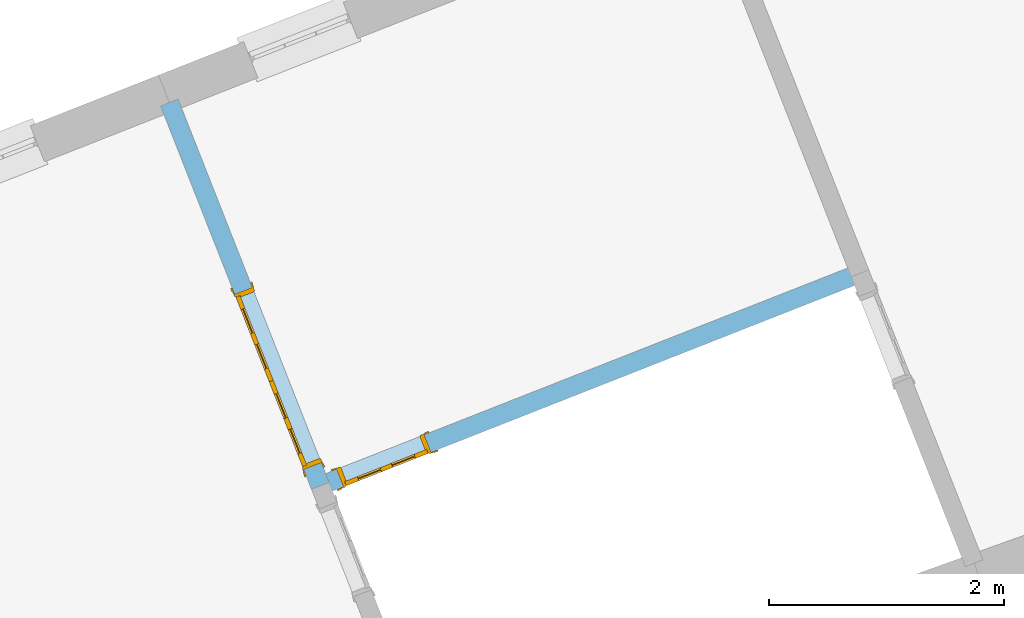
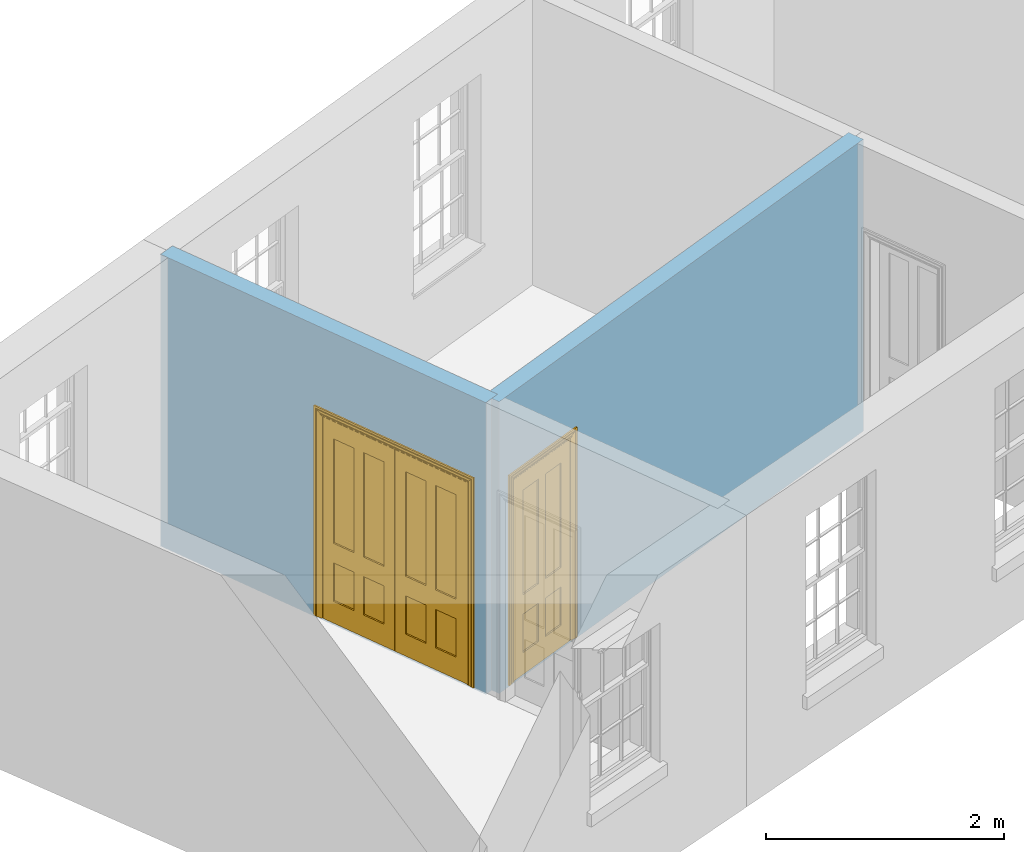
# One storey, part 3 of 6: 2 doors, 2 openings, plus 2 elements that do not belong to this part.
"""IFC2X3 building model written with IfcOpenShell, lengths in metres."""

from ifc_helpers import new_model, si_unit, frame, origin, place, context, subcontext, project, spatial, polyline, outline, extrude, faceted_brep, material, layer, layer_set, layer_usage, element, fill, save


model = new_model("IFC2X3")

# Units and contexts
model_context = context("Model", 3, world=origin())
body_context = subcontext(model_context, "Body", "Model", "MODEL_VIEW")
ifc_project = project(units=[si_unit("PLANEANGLEUNIT", "RADIAN"), si_unit("MASSUNIT", "GRAM", prefix="KILO"), si_unit("FORCEUNIT", "NEWTON", prefix="KILO"), si_unit("LENGTHUNIT", "METRE")], contexts=[model_context])

# Site, building, storey
site_placement = place(None, origin())
site = spatial("IfcSite", under=ifc_project, at=site_placement, CompositionType="ELEMENT")
building_placement = place(None, origin())
building = spatial("IfcBuilding", under=site, at=building_placement, Name="Building plot-4", CompositionType="ELEMENT")
storey_placement = place(None, frame((0.0, 0.0, 6.45)))
storey = spatial("IfcBuildingStorey", under=building, at=storey_placement, Name="Floor 1", CompositionType="ELEMENT", Elevation=6.45)

# Wall, opening, door
ifc_material = material(Name="Masonry")
ifc_layer = layer(ifc_material, 0.16, ventilated=False)
ifc_layer_set = layer_set([ifc_layer], Name="My Wall")
ifc_layer_usage = layer_usage(ifc_layer_set, "AXIS2", "NEGATIVE", 0.08)
wall_1_placement = place(storey_placement, origin())
wall_1 = element("IfcWallStandardCase", 1, at=wall_1_placement, inside=storey, material=ifc_layer_usage, Name="interior", context=body_context, shape_type="SweptSolid", body=[
    extrude(outline(polyline([(53.3188757605398, 50.5174703749296), (53.2602472129912, 50.666341773836), (48.675963659778, 48.860958817468), (48.7345922073266, 48.7120874185616), (53.3188757605398, 50.5174703749296)])), origin(), (0.0, 0.0, 1.0), 3.0),
])
opening_1_placement = place(storey_placement, frame((0.0, 0.0, 0.0199999999999996)))
opening_1 = element("IfcOpeningElement", 2, at=opening_1_placement, cuts=wall_1, Name="Opening", ObjectType="Opening", context=body_context, shape_type="SweptSolid", body=[
    extrude(outline(polyline([(49.5878009780793, 49.2200586712036), (48.8434439835476, 48.9269159334602), (48.9020725310963, 48.7780445345539), (49.646429525628, 49.0711872722973), (49.5878009780793, 49.2200586712036)])), origin(), (0.0, 0.0, 1.0), 2.1),
])
door_1_placement = place(storey_placement, frame((49.6171152518537, 49.1456229717504, 0.0199999999999996), z_axis=(0.0, 0.0, 1.0), x_axis=(-0.744356994531735, -0.293142737743388, 0.0)))
door_1 = element("IfcDoor", 3, at=door_1_placement, inside=storey, Name="living inside door", OverallHeight=2.1, OverallWidth=0.8, context=body_context, shape_type="Brep", held_by="IfcProductRepresentation", body=[
    faceted_brep([(0.773, 0.08, 1.895), (0.66, 0.08, 1.895), (0.66, 0.08, 2.073), (0.773, 0.08, 2.073), (0.773, 0.08, 0.82), (0.66, 0.08, 0.82), (0.45, 0.08, 1.895), (0.45, 0.08, 2.073), (0.773, 0.08, 0.62), (0.66, 0.08, 0.62), (0.66, 0.065, 0.82), (0.66, 0.065, 1.895), (0.45, 0.065, 1.895), (0.35, 0.08, 1.895), (0.35, 0.08, 2.073), (0.773, 0.08, 0.225), (0.66, 0.08, 0.225), (0.45, 0.08, 0.62), (0.45, 0.08, 0.82), (0.45, 0.065, 0.82), (0.35, 0.08, 0.82), (0.14, 0.08, 2.073), (0.14, 0.08, 1.895), (0.773, 0.08, 0.0), (0.66, 0.08, 0.0), (0.66, 0.065, 0.225), (0.66, 0.065, 0.62), (0.45, 0.065, 0.62), (0.35, 0.08, 0.62), (0.35, 0.065, 0.82), (0.35, 0.065, 1.895), (0.14, 0.065, 1.895), (0.027, 0.08, 2.073), (0.027, 0.08, 1.895), (0.773, 0.042, 0.0), (0.66, 0.042, 0.0), (0.45, 0.08, 0.0), (0.45, 0.08, 0.225), (0.45, 0.065, 0.225), (0.35, 0.08, 0.225), (0.14, 0.08, 0.82), (0.14, 0.08, 0.62), (0.14, 0.065, 0.82), (0.027, 0.08, 0.82), (0.773, 0.042, 0.225), (0.66, 0.042, 0.225), (0.45, 0.042, 0.0), (0.35, 0.08, 0.0), (0.35, 0.065, 0.225), (0.35, 0.065, 0.62), (0.14, 0.065, 0.62), (0.027, 0.08, 0.62), (0.773, 0.042, 0.62), (0.66, 0.042, 0.62), (0.45, 0.042, 0.225), (0.35, 0.042, 0.0), (0.14, 0.08, 0.225), (0.14, 0.08, 0.0), (0.14, 0.065, 0.225), (0.027, 0.08, 0.225), (0.773, 0.042, 0.82), (0.66, 0.042, 0.82), (0.66, 0.057, 0.62), (0.66, 0.057, 0.225), (0.45, 0.057, 0.225), (0.35, 0.042, 0.225), (0.14, 0.042, 0.0), (0.027, 0.08, 0.0), (0.773, 0.042, 1.895), (0.66, 0.042, 1.895), (0.45, 0.042, 0.62), (0.45, 0.042, 0.82), (0.45, 0.057, 0.62), (0.35, 0.042, 0.62), (0.14, 0.042, 0.225), (0.027, 0.042, 0.0), (0.773, 0.042, 2.073), (0.66, 0.042, 2.073), (0.66, 0.057, 1.895), (0.66, 0.057, 0.82), (0.45, 0.057, 0.82), (0.35, 0.042, 0.82), (0.35, 0.057, 0.62), (0.35, 0.057, 0.225), (0.14, 0.057, 0.225), (0.027, 0.042, 0.225), (0.45, 0.042, 1.895), (0.45, 0.042, 2.073), (0.45, 0.057, 1.895), (0.35, 0.042, 1.895), (0.14, 0.042, 0.82), (0.14, 0.042, 0.62), (0.14, 0.057, 0.62), (0.027, 0.042, 0.62), (0.35, 0.042, 2.073), (0.35, 0.057, 1.895), (0.35, 0.057, 0.82), (0.14, 0.057, 0.82), (0.027, 0.042, 0.82), (0.14, 0.042, 2.073), (0.14, 0.042, 1.895), (0.14, 0.057, 1.895), (0.027, 0.042, 1.895), (0.027, 0.042, 2.073), (0.02, 0.085, 0.0), (0.005, 0.09, 0.0), (0.005, 0.09, 2.095), (0.02, 0.085, 2.08), (0.02, 0.08, 0.0), (0.0, 0.085, 0.0), (0.0, 0.085, 2.1), (0.795, 0.09, 2.095), (0.78, 0.085, 2.08), (0.02, 0.08, 2.08), (0.0, 0.08, 0.0), (-0.032, 0.095, 0.0), (-0.032, 0.095, 2.132), (0.8, 0.085, 2.1), (0.795, 0.09, 0.0), (0.78, 0.085, 0.0), (0.78, 0.08, 2.08), (0.04, 0.04, 0.0), (0.025, 0.04, 0.0), (0.025, 0.04, 2.075), (0.04, 0.04, 2.06), (-0.04, 0.09, 0.0), (-0.04, 0.09, 2.14), (0.832, 0.095, 2.132), (0.8, 0.085, 0.0), (0.78, 0.08, 0.0), (0.8, 0.08, 0.0), (0.86, 0.08, 0.0), (0.86, 0.08, 2.16), (0.8, 0.08, 2.1), (-0.06, 0.08, 2.16), (0.0, 0.08, 2.1), (-0.06, 0.08, 0.0), (-0.04, 0.095, 0.0), (-0.04, 0.095, 2.14), (0.84, 0.09, 2.14), (0.832, 0.095, 0.0), (0.84, 0.09, 0.0), (0.86, 0.095, 0.0), (0.86, 0.095, 2.16), (-0.06, 0.095, 2.16), (-0.06, 0.095, 0.0), (0.84, 0.095, 0.0), (0.84, 0.095, 2.14), (-0.025, -0.095, 0.0), (-0.025, -0.09, 0.0), (-0.025, -0.09, 2.125), (-0.025, -0.095, 2.125), (-0.017, -0.095, 0.0), (-0.017, -0.095, 2.117), (0.825, -0.09, 2.125), (0.825, -0.095, 2.125), (0.825, -0.095, 0.0), (0.845, -0.095, 0.0), (-0.045, -0.095, 2.145), (-0.045, -0.095, 0.0), (0.845, -0.095, 2.145), (0.015, -0.085, 0.0), (0.015, -0.085, 2.085), (0.817, -0.095, 2.117), (0.825, -0.09, 0.0), (0.845, -0.08, 0.0), (0.845, -0.08, 2.145), (-0.045, -0.08, 2.145), (-0.045, -0.08, 0.0), (0.02, -0.09, 0.0), (0.02, -0.09, 2.08), (0.785, -0.085, 2.085), (0.817, -0.095, 0.0), (0.8, -0.08, 0.0), (0.8, -0.08, 2.1), (0.0, -0.08, 2.1), (0.0, -0.08, 0.0), (0.035, -0.085, 0.0), (0.035, -0.085, 2.065), (0.78, -0.09, 2.08), (0.785, -0.085, 0.0), (0.775, 0.04, 2.075), (0.76, 0.04, 2.06), (0.035, -0.08, 2.065), (0.035, -0.08, 0.0), (0.765, -0.085, 2.065), (0.78, -0.09, 0.0), (0.765, -0.08, 0.0), (0.765, -0.08, 2.065), (0.765, -0.085, 0.0), (0.04, -0.08, 2.06), (0.04, -0.08, 0.0), (0.76, -0.08, 2.06), (0.76, -0.08, 0.0), (0.76, 0.04, 0.0), (0.775, 0.04, 0.0), (0.025, 0.08, 0.0), (0.025, 0.08, 2.075), (0.775, 0.08, 0.0), (0.775, 0.08, 2.075)], [[[0, 1, 2, 3]], [[1, 0, 4, 5]], [[1, 6, 7, 2]], [[8, 9, 5, 4]], [[1, 5, 10, 11]], [[6, 1, 11, 12]], [[6, 13, 14, 7]], [[15, 16, 9, 8]], [[9, 17, 18, 5]], [[5, 18, 19, 10]], [[10, 19, 12, 11]], [[18, 6, 12, 19]], [[18, 20, 13, 6]], [[21, 14, 13, 22]], [[23, 24, 16, 15]], [[9, 16, 25, 26]], [[17, 9, 26, 27]], [[17, 28, 20, 18]], [[13, 20, 29, 30]], [[22, 13, 30, 31]], [[32, 21, 22, 33]], [[34, 35, 24, 23]], [[24, 36, 37, 16]], [[16, 37, 38, 25]], [[25, 38, 27, 26]], [[37, 17, 27, 38]], [[37, 39, 28, 17]], [[40, 20, 28, 41]], [[20, 40, 42, 29]], [[31, 30, 29, 42]], [[40, 22, 31, 42]], [[33, 22, 40, 43]], [[35, 34, 44, 45]], [[35, 46, 36, 24]], [[36, 47, 39, 37]], [[28, 39, 48, 49]], [[41, 28, 49, 50]], [[43, 40, 41, 51]], [[45, 44, 52, 53]], [[46, 35, 45, 54]], [[46, 55, 47, 36]], [[56, 39, 47, 57]], [[39, 56, 58, 48]], [[50, 49, 48, 58]], [[56, 41, 50, 58]], [[51, 41, 56, 59]], [[53, 52, 60, 61]], [[45, 53, 62, 63]], [[54, 45, 63, 64]], [[55, 46, 54, 65]], [[55, 66, 57, 47]], [[59, 56, 57, 67]], [[61, 60, 68, 69]], [[70, 53, 61, 71]], [[53, 70, 72, 62]], [[72, 64, 63, 62]], [[70, 54, 64, 72]], [[65, 54, 70, 73]], [[65, 74, 66, 55]], [[67, 57, 66, 75]], [[69, 68, 76, 77]], [[61, 69, 78, 79]], [[71, 61, 79, 80]], [[73, 70, 71, 81]], [[65, 73, 82, 83]], [[74, 65, 83, 84]], [[74, 85, 75, 66]], [[86, 69, 77, 87]], [[69, 86, 88, 78]], [[88, 80, 79, 78]], [[86, 71, 80, 88]], [[81, 71, 86, 89]], [[73, 81, 90, 91]], [[73, 91, 92, 82]], [[83, 82, 92, 84]], [[91, 74, 84, 92]], [[91, 93, 85, 74]], [[89, 86, 87, 94]], [[81, 89, 95, 96]], [[90, 81, 96, 97]], [[90, 98, 93, 91]], [[94, 99, 100, 89]], [[89, 100, 101, 95]], [[101, 97, 96, 95]], [[100, 90, 97, 101]], [[100, 102, 98, 90]], [[99, 103, 102, 100]], [[32, 103, 99, 21]], [[102, 103, 32, 33]], [[98, 102, 33, 43]], [[21, 99, 94, 14]], [[94, 87, 7, 14]], [[7, 87, 77, 2]], [[76, 3, 2, 77]], [[43, 51, 93, 98]], [[51, 59, 85, 93]], [[67, 75, 85, 59]], [[34, 23, 15, 44]], [[44, 15, 8, 52]], [[52, 8, 4, 60]], [[0, 68, 60, 4]], [[0, 3, 76, 68]], [[104, 105, 106, 107]], [[104, 108, 109, 105]], [[105, 109, 110, 106]], [[107, 106, 111, 112]], [[107, 113, 108, 104]], [[114, 109, 108]], [[109, 115, 116, 110]], [[106, 110, 117, 111]], [[112, 111, 118, 119]], [[113, 107, 112, 120]], [[121, 122, 123, 124]], [[115, 109, 114, 125]], [[115, 125, 126, 116]], [[110, 116, 127, 117]], [[111, 117, 128, 118]], [[118, 128, 129, 119]], [[120, 112, 119, 129]], [[130, 129, 128]], [[130, 131, 132, 133]], [[133, 132, 134, 135]], [[135, 134, 136, 114]], [[136, 125, 114]], [[125, 137, 138, 126]], [[116, 126, 139, 127]], [[117, 127, 140, 128]], [[141, 130, 128, 140]], [[131, 130, 141]], [[131, 142, 143, 132]], [[132, 143, 144, 134]], [[134, 144, 145, 136]], [[137, 125, 136, 145]], [[143, 142, 146]], [[143, 146, 147]], [[137, 145, 144]], [[143, 147, 138]], [[138, 137, 144]], [[143, 138, 144]], [[126, 138, 147, 139]], [[127, 139, 141, 140]], [[142, 131, 141, 146]], [[139, 147, 146, 141]], [[148, 149, 150, 151]], [[149, 152, 153, 150]], [[151, 150, 154, 155]], [[155, 156, 157]], [[158, 159, 148]], [[158, 148, 151]], [[155, 157, 160]], [[158, 151, 155]], [[155, 160, 158]], [[152, 161, 162, 153]], [[150, 153, 163, 154]], [[155, 154, 164, 156]], [[156, 164, 165, 157]], [[157, 165, 166, 160]], [[160, 166, 167, 158]], [[158, 167, 168, 159]], [[161, 169, 170, 162]], [[153, 162, 171, 163]], [[154, 163, 172, 164]], [[165, 164, 173]], [[165, 173, 174, 166]], [[166, 174, 175, 167]], [[167, 175, 176, 168]], [[169, 177, 178, 170]], [[162, 170, 179, 171]], [[163, 171, 180, 172]], [[172, 180, 173, 164]], [[124, 123, 181, 182]], [[183, 178, 177, 184]], [[170, 178, 185, 179]], [[171, 179, 186, 180]], [[187, 173, 180]], [[185, 188, 187, 189]], [[188, 185, 178, 183]], [[179, 185, 189, 186]], [[189, 187, 180, 186]], [[190, 183, 184, 191]], [[192, 188, 183, 190]], [[191, 184, 122, 121]], [[124, 190, 191, 121]], [[193, 187, 188, 192]], [[182, 192, 190, 124]], [[184, 176, 122]], [[194, 195, 187, 193]], [[192, 182, 194, 193]], [[161, 176, 184]], [[114, 108, 122, 176]], [[173, 187, 195]], [[152, 149, 176, 161]], [[169, 161, 184, 177]], [[196, 122, 108]], [[176, 175, 135, 114]], [[173, 195, 129, 130]], [[176, 149, 168]], [[123, 122, 196, 197]], [[196, 108, 113, 197]], [[175, 174, 133, 135]], [[198, 129, 195]], [[133, 174, 173, 130]], [[159, 168, 149, 148]], [[181, 123, 197, 199]], [[197, 113, 120, 199]], [[199, 120, 129, 198]], [[195, 181, 199, 198]], [[195, 194, 182, 181]]]),
])
fill(opening_1, door_1)

wall_2_placement = place(storey_placement, origin())
wall_2 = element("IfcWallStandardCase", 4, at=wall_2_placement, inside=storey, material=ifc_layer_usage, Name="interior", context=body_context, shape_type="SweptSolid", body=[
    extrude(outline(polyline([(48.6308422340991, 48.7572088442405), (48.7797136330055, 48.8158373917891), (47.4975299405106, 52.0715973916108), (47.3486585416042, 52.0129688440622), (48.6308422340991, 48.7572088442405)])), origin(), (0.0, 0.0, 1.0), 3.0),
])
opening_2_placement = place(storey_placement, frame((0.0, 0.0, 0.0199999999999996)))
opening_2 = element("IfcOpeningElement", 5, at=opening_2_placement, cuts=wall_2, Name="Opening", ObjectType="Opening", context=body_context, shape_type="SweptSolid", body=[
    extrude(outline(polyline([(48.7137565170132, 48.9833177155588), (48.1274710415265, 50.4720317046222), (47.9785996426201, 50.4134031570736), (48.5648851181069, 48.9246891680101), (48.7137565170132, 48.9833177155588)])), origin(), (0.0, 0.0, 1.0), 2.1),
])
door_2_placement = place(storey_placement, frame((48.63932081756, 48.9540034417844, 0.0199999999999996), z_axis=(0.0, 0.0, 1.0), x_axis=(-0.586285475486754, 1.48871398906347, 0.0)))
door_2 = element("IfcDoor", 6, at=door_2_placement, inside=storey, Name="kitchen living inside door", OverallHeight=2.1, OverallWidth=1.6, context=body_context, shape_type="Brep", held_by="IfcProductRepresentation", body=[
    faceted_brep([(0.14, 0.057, 1.895), (0.14, 0.057, 0.82), (0.363, 0.057, 0.82), (0.363, 0.057, 1.895), (0.14, 0.042, 1.895), (0.14, 0.042, 0.82), (0.363, 0.042, 0.82), (0.363, 0.042, 1.895), (0.027, 0.042, 1.895), (0.027, 0.042, 0.82), (0.363, 0.042, 0.62), (0.14, 0.042, 0.62), (0.463, 0.042, 0.82), (0.463, 0.042, 1.895), (0.363, 0.042, 2.073), (0.14, 0.042, 2.073), (0.027, 0.042, 2.073), (0.027, 0.08, 1.895), (0.027, 0.08, 0.82), (0.027, 0.042, 0.62), (0.463, 0.042, 0.62), (0.14, 0.057, 0.62), (0.363, 0.057, 0.62), (0.463, 0.057, 0.82), (0.463, 0.057, 1.895), (0.463, 0.042, 2.073), (0.14, 0.08, 2.073), (0.363, 0.08, 2.073), (0.027, 0.08, 2.073), (0.14, 0.08, 1.895), (0.14, 0.08, 0.82), (0.027, 0.08, 0.62), (0.027, 0.042, 0.225), (0.14, 0.042, 0.225), (0.363, 0.042, 0.225), (0.463, 0.042, 0.225), (0.686, 0.042, 0.62), (0.686, 0.042, 0.82), (0.14, 0.057, 0.225), (0.363, 0.057, 0.225), (0.686, 0.057, 0.82), (0.686, 0.057, 1.895), (0.686, 0.042, 1.895), (0.686, 0.042, 2.073), (0.463, 0.08, 2.073), (0.363, 0.08, 1.895), (0.14, 0.065, 1.895), (0.14, 0.065, 0.82), (0.14, 0.08, 0.62), (0.027, 0.08, 0.225), (0.027, 0.042, 0.0), (0.14, 0.042, 0.0), (0.363, 0.042, 0.0), (0.463, 0.042, 0.0), (0.463, 0.057, 0.225), (0.463, 0.057, 0.62), (0.686, 0.057, 0.62), (0.799, 0.042, 0.62), (0.799, 0.042, 0.82), (0.799, 0.042, 1.895), (0.799, 0.042, 2.073), (0.686, 0.08, 2.073), (0.463, 0.08, 1.895), (0.363, 0.065, 1.895), (0.363, 0.065, 0.82), (0.363, 0.08, 0.82), (0.363, 0.08, 0.62), (0.14, 0.08, 0.225), (0.027, 0.08, 0.0), (0.14, 0.08, 0.0), (0.363, 0.08, 0.0), (0.463, 0.08, 0.0), (0.686, 0.042, 0.0), (0.686, 0.042, 0.225), (0.686, 0.057, 0.225), (0.799, 0.042, 0.225), (0.799, 0.08, 0.62), (0.799, 0.08, 0.82), (0.799, 0.08, 1.895), (0.799, 0.08, 2.073), (0.686, 0.08, 1.895), (0.463, 0.08, 0.82), (0.463, 0.08, 0.62), (0.363, 0.065, 0.62), (0.14, 0.065, 0.62), (0.14, 0.065, 0.225), (0.363, 0.08, 0.225), (0.463, 0.08, 0.225), (0.686, 0.08, 0.0), (0.799, 0.042, 0.0), (0.799, 0.08, 0.225), (0.686, 0.08, 0.62), (0.686, 0.08, 0.82), (0.686, 0.065, 1.895), (0.463, 0.065, 1.895), (0.463, 0.065, 0.82), (0.363, 0.065, 0.225), (0.686, 0.08, 0.225), (0.799, 0.08, 0.0), (0.686, 0.065, 0.82), (0.463, 0.065, 0.62), (0.463, 0.065, 0.225), (0.686, 0.065, 0.62), (0.686, 0.065, 0.225), (1.46, 0.08, 1.895), (1.237, 0.08, 1.895), (1.237, 0.08, 2.073), (1.46, 0.08, 2.073), (1.46, 0.065, 1.895), (1.237, 0.065, 1.895), (1.137, 0.08, 1.895), (1.137, 0.08, 2.073), (1.237, 0.042, 2.073), (1.46, 0.042, 2.073), (1.573, 0.08, 1.895), (1.573, 0.08, 2.073), (1.46, 0.08, 0.82), (1.46, 0.065, 0.82), (1.237, 0.065, 0.82), (1.237, 0.08, 0.82), (1.137, 0.08, 0.82), (0.914, 0.08, 2.073), (0.914, 0.08, 1.895), (1.137, 0.042, 2.073), (1.237, 0.042, 1.895), (1.46, 0.042, 1.895), (1.573, 0.042, 2.073), (1.573, 0.08, 0.82), (1.573, 0.042, 1.895), (1.237, 0.08, 0.62), (1.137, 0.08, 0.62), (1.137, 0.065, 0.82), (1.137, 0.065, 1.895), (0.914, 0.042, 2.073), (0.914, 0.065, 1.895), (0.801, 0.08, 2.073), (0.801, 0.08, 1.895), (1.137, 0.042, 1.895), (1.237, 0.057, 1.895), (1.46, 0.057, 1.895), (1.573, 0.042, 0.82), (1.573, 0.08, 0.62), (1.46, 0.08, 0.62), (1.237, 0.08, 0.225), (1.137, 0.08, 0.225), (0.914, 0.08, 0.82), (0.914, 0.08, 0.62), (0.914, 0.065, 0.82), (0.801, 0.042, 2.073), (0.914, 0.042, 1.895), (0.801, 0.08, 0.82), (0.801, 0.042, 1.895), (1.137, 0.042, 0.82), (1.237, 0.042, 0.82), (1.237, 0.057, 0.82), (1.46, 0.057, 0.82), (1.46, 0.042, 0.82), (1.573, 0.042, 0.62), (1.573, 0.08, 0.225), (1.46, 0.08, 0.225), (1.46, 0.065, 0.62), (1.237, 0.065, 0.62), (1.237, 0.08, 0.0), (1.137, 0.08, 0.0), (1.137, 0.065, 0.225), (1.137, 0.065, 0.62), (1.237, 0.065, 0.225), (0.914, 0.065, 0.62), (0.801, 0.08, 0.62), (0.914, 0.057, 1.895), (1.137, 0.057, 1.895), (0.801, 0.042, 0.82), (1.137, 0.042, 0.62), (1.237, 0.042, 0.62), (1.137, 0.057, 0.82), (1.46, 0.042, 0.62), (1.573, 0.042, 0.225), (1.573, 0.08, 0.0), (1.46, 0.08, 0.0), (1.46, 0.065, 0.225), (1.237, 0.042, 0.0), (1.137, 0.042, 0.0), (0.914, 0.08, 0.225), (0.914, 0.08, 0.0), (0.914, 0.065, 0.225), (0.801, 0.08, 0.225), (0.801, 0.042, 0.62), (0.914, 0.042, 0.82), (0.914, 0.057, 0.82), (1.137, 0.042, 0.225), (1.237, 0.042, 0.225), (0.914, 0.042, 0.62), (1.46, 0.042, 0.225), (1.573, 0.042, 0.0), (1.46, 0.042, 0.0), (0.914, 0.042, 0.0), (0.801, 0.08, 0.0), (0.801, 0.042, 0.225), (1.237, 0.057, 0.225), (1.237, 0.057, 0.62), (1.137, 0.057, 0.62), (1.137, 0.057, 0.225), (1.46, 0.057, 0.62), (0.914, 0.057, 0.62), (1.46, 0.057, 0.225), (0.914, 0.042, 0.225), (0.801, 0.042, 0.0), (0.914, 0.057, 0.225), (0.02, 0.085, 0.0), (0.005, 0.09, 0.0), (0.005, 0.09, 2.095), (0.02, 0.085, 2.08), (0.02, 0.08, 0.0), (0.0, 0.085, 0.0), (0.0, 0.085, 2.1), (1.595, 0.09, 2.095), (1.58, 0.085, 2.08), (0.02, 0.08, 2.08), (0.0, 0.08, 0.0), (-0.032, 0.095, 0.0), (-0.032, 0.095, 2.132), (1.6, 0.085, 2.1), (1.595, 0.09, 0.0), (1.58, 0.085, 0.0), (1.58, 0.08, 2.08), (0.025, 0.08, 0.0), (0.025, 0.08, 2.075), (-0.04, 0.09, 0.0), (0.025, 0.04, 0.0), (0.0, -0.08, 0.0), (-0.04, 0.09, 2.14), (1.632, 0.095, 2.132), (1.6, 0.085, 0.0), (1.58, 0.08, 0.0), (1.575, 0.08, 2.075), (0.025, 0.04, 2.075), (-0.06, 0.08, 0.0), (0.035, -0.08, 0.0), (0.0, -0.08, 2.1), (0.0, 0.08, 2.1), (-0.04, 0.095, 0.0), (-0.04, 0.095, 2.14), (1.64, 0.09, 2.14), (1.632, 0.095, 0.0), (1.6, 0.08, 0.0), (1.575, 0.08, 0.0), (1.575, 0.04, 2.075), (0.04, 0.04, 0.0), (0.04, 0.04, 2.06), (-0.06, 0.095, 0.0), (-0.06, 0.08, 2.16), (0.015, -0.085, 0.0), (0.04, -0.08, 0.0), (-0.045, -0.08, 2.145), (-0.045, -0.08, 0.0), (1.6, -0.08, 2.1), (1.6, 0.08, 2.1), (-0.06, 0.095, 2.16), (1.64, 0.095, 2.14), (1.64, 0.09, 0.0), (1.6, -0.08, 0.0), (1.575, 0.04, 0.0), (1.56, 0.04, 2.06), (0.04, -0.08, 2.06), (1.66, 0.08, 2.16), (-0.017, -0.095, 0.0), (-0.025, -0.09, 0.0), (0.02, -0.09, 0.0), (0.035, -0.085, 0.0), (0.035, -0.08, 2.065), (1.645, -0.08, 2.145), (-0.045, -0.095, 2.145), (-0.045, -0.095, 0.0), (1.66, 0.095, 2.16), (1.64, 0.095, 0.0), (1.66, 0.08, 0.0), (1.565, -0.08, 0.0), (1.56, 0.04, 0.0), (1.56, -0.08, 2.06), (-0.017, -0.095, 2.117), (-0.025, -0.09, 2.125), (0.015, -0.085, 2.085), (0.02, -0.09, 2.08), (0.035, -0.085, 2.065), (1.565, -0.08, 2.065), (1.645, -0.08, 0.0), (1.645, -0.095, 2.145), (-0.025, -0.095, 0.0), (1.66, 0.095, 0.0), (1.585, -0.085, 0.0), (1.56, -0.08, 0.0), (1.617, -0.095, 2.117), (1.625, -0.09, 2.125), (-0.025, -0.095, 2.125), (1.585, -0.085, 2.085), (1.58, -0.09, 2.08), (1.565, -0.085, 2.065), (1.625, -0.09, 0.0), (1.645, -0.095, 0.0), (1.625, -0.095, 2.125), (1.617, -0.095, 0.0), (1.565, -0.085, 0.0), (1.58, -0.09, 0.0), (1.625, -0.095, 0.0)], [[[0, 1, 2, 3]], [[1, 0, 4, 5]], [[2, 1, 5, 6]], [[6, 7, 3, 2]], [[7, 4, 0, 3]], [[4, 8, 9, 5]], [[10, 6, 5, 11]], [[6, 12, 13, 7]], [[14, 15, 4, 7]], [[15, 16, 8, 4]], [[9, 8, 17, 18]], [[5, 9, 19, 11]], [[10, 20, 12, 6]], [[10, 11, 21, 22]], [[13, 12, 23, 24]], [[7, 13, 25, 14]], [[26, 15, 14, 27]], [[28, 16, 15, 26]], [[8, 16, 28, 17]], [[17, 29, 30, 18]], [[18, 31, 19, 9]], [[11, 19, 32, 33]], [[34, 35, 20, 10]], [[20, 36, 37, 12]], [[11, 33, 38, 21]], [[39, 22, 21, 38]], [[34, 10, 22, 39]], [[12, 37, 40, 23]], [[24, 23, 40, 41]], [[42, 13, 24, 41]], [[13, 42, 43, 25]], [[14, 25, 44, 27]], [[26, 27, 45, 29]], [[28, 26, 29, 17]], [[30, 29, 46, 47]], [[18, 30, 48, 31]], [[31, 49, 32, 19]], [[33, 32, 50, 51]], [[52, 53, 35, 34]], [[20, 35, 54, 55]], [[36, 20, 55, 56]], [[36, 57, 58, 37]], [[33, 34, 39, 38]], [[37, 42, 41, 40]], [[42, 59, 60, 43]], [[44, 25, 43, 61]], [[62, 45, 27, 44]], [[29, 45, 63, 46]], [[46, 63, 64, 47]], [[65, 30, 47, 64]], [[30, 65, 66, 48]], [[31, 48, 67, 49]], [[68, 50, 32, 49]], [[68, 69, 51, 50]], [[34, 33, 51, 52]], [[53, 52, 70, 71]], [[53, 72, 73, 35]], [[35, 73, 74, 54]], [[55, 54, 74, 56]], [[73, 36, 56, 74]], [[73, 75, 57, 36]], [[57, 76, 77, 58]], [[37, 58, 59, 42]], [[78, 79, 60, 59]], [[60, 79, 61, 43]], [[80, 62, 44, 61]], [[81, 65, 45, 62]], [[45, 65, 64, 63]], [[82, 66, 65, 81]], [[48, 66, 83, 84]], [[67, 48, 84, 85]], [[49, 67, 69, 68]], [[52, 51, 69, 70]], [[71, 70, 86, 87]], [[72, 53, 71, 88]], [[72, 89, 75, 73]], [[75, 90, 76, 57]], [[76, 91, 92, 77]], [[78, 59, 58, 77]], [[78, 80, 61, 79]], [[62, 80, 93, 94]], [[81, 62, 94, 95]], [[87, 86, 66, 82]], [[91, 82, 81, 92]], [[66, 86, 96, 83]], [[84, 83, 96, 85]], [[86, 67, 85, 96]], [[67, 86, 70, 69]], [[88, 71, 87, 97]], [[89, 72, 88, 98]], [[89, 98, 90, 75]], [[90, 97, 91, 76]], [[80, 78, 77, 92]], [[80, 92, 99, 93]], [[99, 95, 94, 93]], [[92, 81, 95, 99]], [[87, 82, 100, 101]], [[82, 91, 102, 100]], [[97, 87, 101, 103]], [[98, 88, 97, 90]], [[91, 97, 103, 102]], [[103, 101, 100, 102]], [[104, 105, 106, 107]], [[105, 104, 108, 109]], [[105, 110, 111, 106]], [[106, 112, 113, 107]], [[114, 104, 107, 115]], [[104, 116, 117, 108]], [[117, 118, 109, 108]], [[119, 105, 109, 118]], [[119, 120, 110, 105]], [[121, 111, 110, 122]], [[123, 112, 106, 111]], [[124, 125, 113, 112]], [[126, 115, 107, 113]], [[104, 114, 127, 116]], [[114, 115, 126, 128]], [[116, 119, 118, 117]], [[129, 130, 120, 119]], [[110, 120, 131, 132]], [[121, 133, 123, 111]], [[122, 110, 132, 134]], [[135, 121, 122, 136]], [[137, 124, 112, 123]], [[125, 124, 138, 139]], [[125, 128, 126, 113]], [[114, 128, 140, 127]], [[141, 142, 116, 127]], [[142, 129, 119, 116]], [[143, 144, 130, 129]], [[145, 120, 130, 146]], [[120, 145, 147, 131]], [[134, 132, 131, 147]], [[135, 148, 133, 121]], [[123, 133, 149, 137]], [[145, 122, 134, 147]], [[136, 122, 145, 150]], [[151, 148, 135, 136]], [[152, 153, 124, 137]], [[124, 153, 154, 138]], [[138, 154, 155, 139]], [[156, 125, 139, 155]], [[156, 140, 128, 125]], [[157, 141, 127, 140]], [[158, 159, 142, 141]], [[129, 142, 160, 161]], [[162, 163, 144, 143]], [[130, 144, 164, 165]], [[143, 129, 161, 166]], [[146, 130, 165, 167]], [[150, 145, 146, 168]], [[133, 148, 151, 149]], [[137, 149, 169, 170]], [[171, 151, 136, 150]], [[172, 173, 153, 152]], [[152, 137, 170, 174]], [[153, 156, 155, 154]], [[175, 157, 140, 156]], [[176, 158, 141, 157]], [[177, 178, 159, 158]], [[142, 159, 179, 160]], [[179, 166, 161, 160]], [[180, 181, 163, 162]], [[182, 144, 163, 183]], [[178, 162, 143, 159]], [[144, 182, 184, 164]], [[167, 165, 164, 184]], [[159, 143, 166, 179]], [[182, 146, 167, 184]], [[168, 146, 182, 185]], [[150, 168, 186, 171]], [[149, 151, 171, 187]], [[149, 187, 188, 169]], [[169, 188, 174, 170]], [[189, 190, 173, 172]], [[173, 175, 156, 153]], [[172, 152, 187, 191]], [[187, 152, 174, 188]], [[192, 176, 157, 175]], [[193, 177, 158, 176]], [[193, 194, 178, 177]], [[181, 180, 190, 189]], [[181, 195, 183, 163]], [[194, 180, 162, 178]], [[185, 182, 183, 196]], [[168, 185, 197, 186]], [[187, 171, 186, 191]], [[173, 190, 198, 199]], [[189, 172, 200, 201]], [[175, 173, 199, 202]], [[172, 191, 203, 200]], [[194, 193, 176, 192]], [[192, 175, 202, 204]], [[180, 194, 192, 190]], [[189, 205, 195, 181]], [[196, 183, 195, 206]], [[196, 206, 197, 185]], [[191, 186, 197, 205]], [[190, 192, 204, 198]], [[199, 198, 204, 202]], [[201, 200, 203, 207]], [[205, 189, 201, 207]], [[191, 205, 207, 203]], [[205, 197, 206, 195]], [[208, 209, 210, 211]], [[208, 212, 213, 209]], [[209, 213, 214, 210]], [[211, 210, 215, 216]], [[211, 217, 212, 208]], [[218, 213, 212]], [[213, 219, 220, 214]], [[210, 214, 221, 215]], [[216, 215, 222, 223]], [[217, 211, 216, 224]], [[225, 212, 217, 226]], [[219, 213, 218, 227]], [[218, 212, 228, 229]], [[219, 227, 230, 220]], [[214, 220, 231, 221]], [[215, 221, 232, 222]], [[222, 232, 233, 223]], [[224, 216, 223, 233]], [[226, 217, 224, 234]], [[225, 228, 212]], [[235, 228, 225, 226]], [[236, 227, 218]], [[237, 229, 228]], [[229, 238, 239, 218]], [[227, 240, 241, 230]], [[220, 230, 242, 231]], [[221, 231, 243, 232]], [[244, 233, 232]], [[234, 224, 233, 245]], [[246, 235, 226, 234]], [[247, 228, 235, 248]], [[240, 227, 236, 249]], [[239, 250, 236, 218]], [[251, 229, 237]], [[252, 237, 228, 247]], [[253, 238, 229, 254]], [[238, 255, 256, 239]], [[241, 240, 257]], [[230, 241, 258, 242]], [[231, 242, 259, 243]], [[259, 244, 232, 243]], [[260, 261, 233, 244]], [[245, 233, 261]], [[261, 246, 234, 245]], [[248, 235, 246, 262]], [[248, 263, 252, 247]], [[250, 257, 249, 236]], [[240, 249, 257]], [[256, 264, 250, 239]], [[265, 266, 229, 251]], [[267, 251, 237, 268]], [[263, 269, 237, 252]], [[270, 255, 238, 253]], [[229, 266, 254]], [[271, 253, 254, 272]], [[256, 255, 260, 244]], [[273, 241, 257]], [[273, 258, 241]], [[242, 258, 274, 259]], [[275, 244, 259]], [[260, 276, 261]], [[261, 277, 262, 246]], [[262, 278, 263, 248]], [[264, 273, 257, 250]], [[244, 275, 264, 256]], [[266, 265, 279, 280]], [[265, 251, 281, 279]], [[251, 267, 282, 281]], [[269, 283, 268, 237]], [[267, 268, 283, 282]], [[278, 284, 269, 263]], [[285, 260, 255, 270]], [[286, 270, 253, 271]], [[272, 254, 266, 287]], [[271, 272, 287]], [[273, 274, 258]], [[288, 275, 259, 274]], [[276, 260, 289]], [[277, 261, 276, 290]], [[278, 262, 277, 290]], [[275, 288, 273, 264]], [[280, 279, 291, 292]], [[287, 266, 280, 293]], [[279, 281, 294, 291]], [[281, 282, 295, 294]], [[284, 296, 283, 269]], [[282, 283, 296, 295]], [[290, 276, 284, 278]], [[285, 297, 260]], [[298, 285, 270, 286]], [[299, 286, 271]], [[271, 287, 293]], [[273, 288, 274]], [[300, 289, 260, 297]], [[301, 276, 289, 302]], [[292, 291, 300, 297]], [[293, 280, 292, 299]], [[291, 294, 289, 300]], [[294, 295, 302, 289]], [[296, 284, 276, 301]], [[295, 296, 301, 302]], [[303, 297, 285, 298]], [[299, 298, 286]], [[271, 293, 299]], [[299, 292, 297, 303]], [[299, 303, 298]]]),
])
fill(opening_2, door_2)

save(model, "model.ifc")
